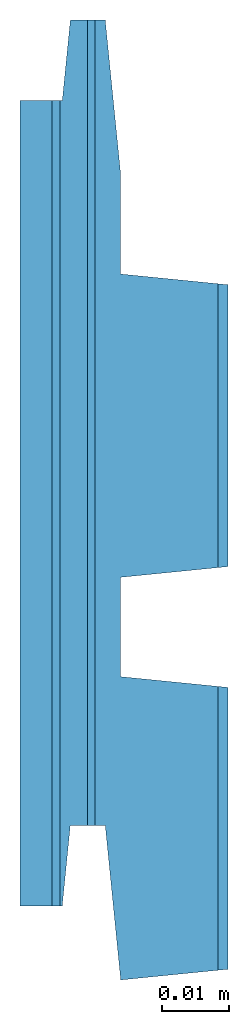
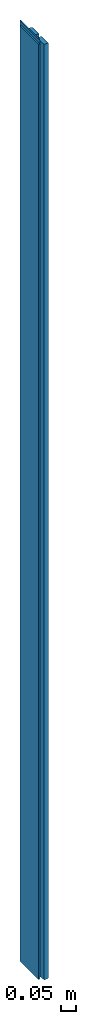
# One storey: 1 beam.
"""IFC2X3 building model written with IfcOpenShell, lengths in metres."""

import ifcopenshell
import ifcopenshell.guid

model = None  # the IFC model being written
_history = None  # IfcOwnerHistory: only IFC2X3 demands one
_inside = {}  # id of a spatial element -> (the spatial element, [elements in it])
_under = {}  # id of a project, library or spatial element -> (it, [spatial elements below it])
_declared = {}  # id of a project -> (the project, [libraries it declares])
_typed = {}  # id of a type object -> (the type object, [elements of that type])
_made_of = {}  # id of a material, layer set ... -> (it, [elements and type objects made of it])


def new_model(schema):
    """Start an empty IFC model of exactly this schema.

    Asked for "IFC4X3", IfcOpenShell would pick the latest addendum, in which some entities
    have other attributes; the version numbers below select the first issue.
    IFC2X3 requires an IfcOwnerHistory on every rooted entity: one is made here for all.
    """
    global model, _history
    if schema == "IFC4X3":
        model = ifcopenshell.file(schema_version=(4, 3, 0, 0))
    else:
        model = ifcopenshell.file(schema=schema)
    _inside.clear()
    _under.clear()
    _declared.clear()
    _typed.clear()
    _made_of.clear()
    _history = None
    if model.schema == "IFC2X3":
        org = make("IfcOrganization", Name="unknown")
        user = make(
            "IfcPersonAndOrganization",
            ThePerson=make("IfcPerson", FamilyName="unknown"),
            TheOrganization=org,
        )
        app = make(
            "IfcApplication",
            ApplicationDeveloper=org,
            Version="unknown",
            ApplicationFullName="unknown",
            ApplicationIdentifier="unknown",
        )
        _history = make(
            "IfcOwnerHistory",
            OwningUser=user,
            OwningApplication=app,
            ChangeAction="ADDED",
            CreationDate=0,
        )
    return model


def make(cls, **values):
    """One entity of the class cls with the attributes given. An attribute that is None is left unset."""
    return model.create_entity(
        cls, **{name: value for name, value in values.items() if value is not None}
    )


def rooted(cls, **values):
    """An entity with a GlobalId (a new one), such as an element, a storey or a relation."""
    return make(cls, GlobalId=ifcopenshell.guid.new(), OwnerHistory=_history, **values)


def si_unit(unit_type, name, prefix=None):
    """IfcSIUnit, for example si_unit("LENGTHUNIT", "METRE", prefix="MILLI")."""
    return make("IfcSIUnit", UnitType=unit_type, Prefix=prefix, Name=name)


def assignment(units):
    """IfcUnitAssignment: the units of a project."""
    return None if units is None else make("IfcUnitAssignment", Units=units)


def point(xyz):
    """IfcCartesianPoint."""
    return None if xyz is None else make("IfcCartesianPoint", Coordinates=xyz)


def direction(xyz):
    """IfcDirection."""
    return None if xyz is None else make("IfcDirection", DirectionRatios=xyz)


def frame(location, z_axis=None, x_axis=None):
    """IfcAxis2Placement3D, a coordinate frame: its origin and axes. An axis left out is left unset."""
    return make(
        "IfcAxis2Placement3D",
        Location=point(location),
        Axis=direction(z_axis),
        RefDirection=direction(x_axis),
    )


def origin_with_axes():
    """The frame at (0, 0, 0) with the z axis (0, 0, 1) and the x axis (1, 0, 0) written out."""
    return frame((0.0, 0.0, 0.0), z_axis=(0.0, 0.0, 1.0), x_axis=(1.0, 0.0, 0.0))


def place(relative_to, where):
    """IfcLocalPlacement: puts the frame where relative to a parent placement (None: the world)."""
    return make(
        "IfcLocalPlacement", PlacementRelTo=relative_to, RelativePlacement=where
    )


def context(
    kind, dimensions, precision=None, world=None, true_north=None, identifier=None
):
    """IfcGeometricRepresentationContext, for example the 3D "Model" context."""
    return make(
        "IfcGeometricRepresentationContext",
        ContextIdentifier=identifier,
        ContextType=kind,
        CoordinateSpaceDimension=dimensions,
        Precision=precision,
        WorldCoordinateSystem=world,
        TrueNorth=true_north,
    )


def project(units=None, contexts=None):
    """IfcProject with its units and contexts."""
    return rooted(
        "IfcProject",
        Name="project",
        RepresentationContexts=contexts,
        UnitsInContext=assignment(units),
    )


def spatial(cls, under=None, at=None, **own):
    """A site, building, storey or space (cls), placed at a placement, below another one or the project."""
    s = rooted(cls, ObjectPlacement=at, **own)
    if under is not None:
        _under.setdefault(under.id(), (under, []))[1].append(s)
    return s


def faces_of(points, faces, orient=None, outer=None):
    """IfcFace entities. A face is a list of loops; a loop is a list of indices into points, from 0.

    orient and outer hold one flag for each loop. By default every Orientation is true, the
    first loop of a face is its IfcFaceOuterBound and the others are IfcFaceBound.
    """
    made = []
    for i, loops in enumerate(faces):
        bounds = []
        for j, loop in enumerate(loops):
            is_outer = j == 0 if outer is None else outer[i][j]
            bounds.append(
                make(
                    "IfcFaceOuterBound" if is_outer else "IfcFaceBound",
                    Bound=make("IfcPolyLoop", Polygon=[points[k] for k in loop]),
                    Orientation=True if orient is None else orient[i][j],
                )
            )
        made.append(make("IfcFace", Bounds=bounds))
    return made


def faceted_brep(points, faces, orient=None, outer=None, voids=None):
    """IfcFacetedBrep: a solid bounded by flat faces; with voids (closed shells), ...WithVoids."""
    shared = [point(p) for p in points]
    hull = make("IfcClosedShell", CfsFaces=faces_of(shared, faces, orient, outer))
    if voids is None:
        return make("IfcFacetedBrep", Outer=hull)
    return make(
        "IfcFacetedBrepWithVoids",
        Outer=hull,
        Voids=[
            make(cls, CfsFaces=faces_of(shared, fs, o, b)) for cls, fs, o, b in voids
        ],
    )


def shape(context_of_items, identifier, shape_type, items):
    """IfcShapeRepresentation: the items that make up one representation, for example the "Body"."""
    return make(
        "IfcShapeRepresentation",
        ContextOfItems=context_of_items,
        RepresentationIdentifier=identifier,
        RepresentationType=shape_type,
        Items=items,
    )


def material(Name=None, Category=None):
    """IfcMaterial."""
    return make("IfcMaterial", Name=Name, Category=Category)


def made_of(thing, what):
    """Note that an element or type object is made of a material, layer set ...; save() writes the relation."""
    if what is not None:
        _made_of.setdefault(what.id(), (what, []))[1].append(thing)
    return thing


def element(
    cls,
    number,
    at=None,
    inside=None,
    cuts=None,
    type_object=None,
    material=None,
    context=None,
    identifier="Body",
    shape_type=None,
    held_by="IfcProductDefinitionShape",
    body=None,
    shapes=None,
    **own,
):
    """One element of the class cls, such as IfcWall. Its Tag is "e" and its number.

    at: its placement. inside: the storey or other place that contains it. cuts: it is an
    opening in that element (IfcRelVoidsElement). A single representation is given by context,
    identifier, shape_type and body (its items); several are given by shapes. held_by: the class
    of the entity that holds the representations. save() writes the other relations.
    """
    e = rooted(cls, Tag="e%d" % number, ObjectPlacement=at, **own)
    if body is not None:
        shapes = [shape(context, identifier, shape_type, body)]
    if shapes is not None:
        e.Representation = make(held_by, Representations=shapes)
    if inside is not None:
        _inside.setdefault(inside.id(), (inside, []))[1].append(e)
    if cuts is not None:
        rooted(
            "IfcRelVoidsElement", RelatingBuildingElement=cuts, RelatedOpeningElement=e
        )
    if type_object is not None:
        _typed.setdefault(type_object.id(), (type_object, []))[1].append(e)
    return made_of(e, material)


def aggregate(whole, parts):
    """IfcRelAggregates: a whole, such as a stair, and the parts it consists of."""
    return rooted("IfcRelAggregates", RelatingObject=whole, RelatedObjects=parts)


def save(model, path):
    """Write the relations noted so far, then the file.

    IfcRelAggregates (storeys below a building ...), IfcRelContainedInSpatialStructure (elements
    in a storey), IfcRelDefinesByType, IfcRelAssociatesMaterial and IfcRelDeclares: one each for
    every whole, place, type object, material and project.
    """
    for whole, parts in _under.values():
        aggregate(whole, parts)
    for where, things in _inside.values():
        rooted(
            "IfcRelContainedInSpatialStructure",
            RelatedElements=things,
            RelatingStructure=where,
        )
    for kind, things in _typed.values():
        rooted("IfcRelDefinesByType", RelatedObjects=things, RelatingType=kind)
    for what, things in _made_of.values():
        rooted("IfcRelAssociatesMaterial", RelatedObjects=things, RelatingMaterial=what)
    for by, libraries in _declared.values():
        rooted("IfcRelDeclares", RelatingContext=by, RelatedDefinitions=libraries)
    model.write(path)


model = new_model("IFC2X3")

# Units and contexts
model_context = context("Model", 3, precision=1e-06, world=origin_with_axes())
ifc_project = project(units=[si_unit("LENGTHUNIT", "METRE"), si_unit("PLANEANGLEUNIT", "RADIAN")], contexts=[model_context])

# Site, building, storey
site_placement = place(None, origin_with_axes())
site = spatial("IfcSite", under=ifc_project, at=site_placement, CompositionType="ELEMENT")
building_placement = place(None, origin_with_axes())
building = spatial("IfcBuilding", under=site, at=building_placement, Name="Building 1", CompositionType="ELEMENT")
storey_placement = place(None, origin_with_axes())
storey = spatial("IfcBuildingStorey", under=building, at=storey_placement, CompositionType="ELEMENT", Elevation=0.0)

# Beam
ifc_material = material()
beam_placement = place(None, frame((0.0155, 0.060475247524942, 3.711500000000033), z_axis=(0.0, -1.0, 0.0), x_axis=(0.0, 0.0, -1.0)))
element("IfcBeam", 1, at=beam_placement, inside=storey, material=ifc_material, context=model_context, shape_type="Brep", body=[
    faceted_brep([(3.711500000000033, 0.014, 0.010075929780351), (3.711500000000033, 0.014, -0.03222475247516), (3.710000000000033, 0.0155, -0.032074752475161), (3.710000000000033, 0.0155, 0.009925929780354), (3.711500000000033, 0.014, 0.070075247524839), (3.711500000000033, 0.014, 0.027774565269321), (3.710000000000033, 0.0155, 0.027924565269324), (3.710000000000033, 0.0155, 0.06992524752484), (3.711500000000033, 0.014, 0.027774565269321), (3.711500000000033, -0.000499999999996, 0.026324565269281), (0.011500000000009, -0.000499999999996, 0.026324565269281), (0.011500000000009, 0.014, 0.027774565269324), (0.01300000000001, 0.015500000000001, 0.027924565269324), (3.710000000000033, 0.0155, 0.027924565269324), (3.711500000000033, 0.014, -0.03222475247516), (3.711500000000033, -0.0005, -0.03367475247516), (0.011500000000009, -0.000499999999999, -0.03367475247516), (0.011500000000009, 0.014, -0.03222475247516), (0.01300000000001, 0.015500000000001, -0.032074752475161), (3.710000000000033, 0.0155, -0.032074752475161), (3.711500000000033, 0.014, 0.070075247524839), (3.711500000000033, -0.000495049502642, 0.071524752475105), (3.711500000000033, -0.002800000000024, 0.048475247524906), (3.711500000000033, -0.004301496268633, 0.048475247524908), (3.711500000000033, -0.004301496268633, -0.071524752475099), (3.711500000000033, -0.002800000000024, -0.071524752475104), (3.711500000000033, -0.0005, -0.048524752474401), (3.711500000000033, -0.0005, -0.03367475247516), (3.711500000000033, 0.014, -0.03222475247516), (3.711500000000033, 0.014, 0.010075929780351), (3.711500000000033, -0.000499999999997, 0.011525929780318), (3.711500000000033, -0.000499999999996, 0.026324565269281), (3.711500000000033, 0.014, 0.027774565269321), (3.711500000000033, -0.004301496268633, -0.071524752475099), (3.711500000000033, -0.004301496268633, 0.048475247524908), (3.699999999999999, -0.005451496268547, 0.048475247524909), (3.699999999999999, -0.005451496268547, -0.071524752475095), (3.699999999999999, -0.009548503728395, 0.060475247524943), (3.699999999999999, -0.009548503728395, -0.059524752475056), (3.699999999999999, -0.009200000000012, -0.059524752475056), (3.699999999999999, -0.008000000000065, -0.071524752475085), (3.699999999999999, -0.005451496268547, -0.071524752475095), (3.699999999999999, -0.005451496268547, 0.048475247524909), (3.699999999999999, -0.008000000000065, 0.048475247524915), (3.699999999999999, -0.009200000000012, 0.060475247524943), (3.699999999999999, -0.009548503728395, -0.059524752475056), (3.699999999999999, -0.009548503728395, 0.060475247524943), (3.711500000000033, -0.010698503728365, 0.060475247524943), (3.711500000000033, -0.010698503728365, -0.059524752475056), (0.0, -0.008000000000064, -0.071524752475085), (0.0, -0.005451496268546, -0.071524752475095), (0.011500000000009, -0.004301496268628, -0.071524752475099), (0.011500000000009, -0.002800000000023, -0.071524752475106), (3.711500000000033, -0.002800000000024, -0.071524752475104), (3.711500000000033, -0.004301496268633, -0.071524752475099), (3.699999999999999, -0.005451496268547, -0.071524752475095), (3.699999999999999, -0.008000000000065, -0.071524752475085), (0.0, -0.008000000000064, -0.071524752475085), (3.699999999999999, -0.008000000000065, -0.071524752475085), (3.699999999999999, -0.009200000000012, -0.059524752475056), (0.0, -0.009200000000011, -0.059524752475056), (3.711500000000033, -0.015500000000001, -0.059524752475056), (0.011500000000033, -0.0155, -0.059524752475056), (0.011500000000033, -0.010698503728364, -0.059524752475056), (0.0, -0.009548503728394, -0.059524752475056), (0.0, -0.009200000000011, -0.059524752475056), (3.699999999999999, -0.009200000000012, -0.059524752475056), (3.699999999999999, -0.009548503728395, -0.059524752475056), (3.711500000000033, -0.010698503728365, -0.059524752475056), (3.711500000000033, -0.015500000000001, -0.059524752475056), (3.711500000000033, -0.010698503728365, -0.059524752475056), (3.711500000000033, -0.010698503728365, 0.060475247524943), (3.711500000000033, -0.015500000000001, 0.060475247524943), (3.710000000000033, 0.0155, -0.032074752475161), (0.01300000000001, 0.015500000000001, -0.032074752475161), (0.01300000000001, 0.015500000000001, 0.009925929780354), (3.710000000000033, 0.0155, 0.009925929780354), (3.710000000000033, 0.0155, 0.009925929780354), (0.01300000000001, 0.015500000000001, 0.009925929780354), (0.011500000000009, 0.014, 0.010075929780355), (0.011500000000009, -0.000499999999996, 0.011525929780318), (3.711500000000033, -0.000499999999997, 0.011525929780318), (3.711500000000033, 0.014, 0.010075929780351), (3.711500000000033, -0.000499999999997, 0.011525929780318), (0.011500000000009, -0.000499999999996, 0.011525929780318), (0.011500000000009, -0.000499999999996, 0.026324565269281), (3.711500000000033, -0.000499999999996, 0.026324565269281), (3.710000000000033, 0.0155, 0.027924565269324), (0.01300000000001, 0.015500000000001, 0.027924565269324), (0.01300000000001, 0.015500000000001, 0.06992524752484), (3.710000000000033, 0.0155, 0.06992524752484), (0.0, -0.009200000000011, 0.060475247524943), (3.699999999999999, -0.009200000000012, 0.060475247524943), (3.699999999999999, -0.008000000000065, 0.048475247524915), (0.0, -0.008000000000064, 0.048475247524915), (0.0, -0.009548503728394, 0.060475247524943), (0.011500000000033, -0.010698503728364, 0.060475247524943), (0.011500000000033, -0.0155, 0.060475247524943), (3.711500000000033, -0.015500000000001, 0.060475247524943), (3.711500000000033, -0.010698503728365, 0.060475247524943), (3.699999999999999, -0.009548503728395, 0.060475247524943), (3.699999999999999, -0.009200000000012, 0.060475247524943), (0.0, -0.009200000000011, 0.060475247524943), (0.0, -0.005451496268546, 0.048475247524909), (0.0, -0.005451496268546, -0.071524752475095), (0.0, -0.008000000000064, -0.071524752475085), (0.0, -0.009200000000011, -0.059524752475056), (0.0, -0.009548503728394, -0.059524752475056), (0.0, -0.009548503728394, 0.060475247524943), (0.0, -0.009200000000011, 0.060475247524943), (0.0, -0.008000000000064, 0.048475247524915), (0.011500000000009, -0.000499999999999, -0.048524752474403), (0.011500000000009, -0.000499999999999, -0.03367475247516), (3.711500000000033, -0.0005, -0.03367475247516), (3.711500000000033, -0.0005, -0.048524752474401), (3.711500000000033, -0.002800000000024, -0.071524752475104), (0.011500000000009, -0.002800000000023, -0.071524752475106), (0.011500000000009, -0.000499999999999, -0.048524752474403), (3.711500000000033, -0.0005, -0.048524752474401), (0.011500000000009, -0.002800000000023, 0.048475247524906), (0.011500000000009, -0.004301496268628, 0.048475247524908), (0.0, -0.005451496268546, 0.048475247524909), (0.0, -0.008000000000064, 0.048475247524915), (3.699999999999999, -0.008000000000065, 0.048475247524915), (3.699999999999999, -0.005451496268547, 0.048475247524909), (3.711500000000033, -0.004301496268633, 0.048475247524908), (3.711500000000033, -0.002800000000024, 0.048475247524906), (0.011500000000009, -0.000495049502641, 0.071524752475103), (0.011500000000009, -0.002800000000023, 0.048475247524906), (3.711500000000033, -0.002800000000024, 0.048475247524906), (3.711500000000033, -0.000495049502642, 0.071524752475105), (3.710000000000033, 0.0155, 0.06992524752484), (0.01300000000001, 0.015500000000001, 0.06992524752484), (0.011500000000009, 0.014, 0.070075247524839), (0.011500000000009, -0.000495049502641, 0.071524752475103), (3.711500000000033, -0.000495049502642, 0.071524752475105), (3.711500000000033, 0.014, 0.070075247524839), (3.711500000000033, -0.015500000000001, 0.060475247524943), (0.011500000000033, -0.0155, 0.060475247524943), (0.011500000000033, -0.0155, -0.059524752475056), (3.711500000000033, -0.015500000000001, -0.059524752475056), (0.011500000000009, 0.014, 0.070075247524839), (0.01300000000001, 0.015500000000001, 0.06992524752484), (0.01300000000001, 0.015500000000001, 0.027924565269324), (0.011500000000009, 0.014, 0.027774565269324), (0.011500000000033, -0.010698503728364, 0.060475247524943), (0.0, -0.009548503728394, 0.060475247524943), (0.0, -0.009548503728394, -0.059524752475056), (0.011500000000033, -0.010698503728364, -0.059524752475056), (0.011500000000009, -0.000499999999996, 0.026324565269281), (0.011500000000009, -0.000499999999996, 0.011525929780318), (0.011500000000009, 0.014, 0.010075929780355), (0.011500000000009, 0.014, -0.03222475247516), (0.011500000000009, -0.000499999999999, -0.03367475247516), (0.011500000000009, -0.000499999999999, -0.048524752474403), (0.011500000000009, -0.002800000000023, -0.071524752475106), (0.011500000000009, -0.004301496268628, -0.071524752475099), (0.011500000000009, -0.004301496268628, 0.048475247524908), (0.011500000000009, -0.002800000000023, 0.048475247524906), (0.011500000000009, -0.000495049502641, 0.071524752475103), (0.011500000000009, 0.014, 0.070075247524839), (0.011500000000009, 0.014, 0.027774565269324), (0.011500000000009, 0.014, -0.03222475247516), (0.011500000000009, 0.014, 0.010075929780355), (0.01300000000001, 0.015500000000001, 0.009925929780354), (0.01300000000001, 0.015500000000001, -0.032074752475161), (0.0, -0.005451496268546, -0.071524752475095), (0.0, -0.005451496268546, 0.048475247524909), (0.011500000000009, -0.004301496268628, 0.048475247524908), (0.011500000000009, -0.004301496268628, -0.071524752475099), (0.011500000000033, -0.0155, -0.059524752475056), (0.011500000000033, -0.0155, 0.060475247524943), (0.011500000000033, -0.010698503728364, 0.060475247524943), (0.011500000000033, -0.010698503728364, -0.059524752475056)], [[[0, 1, 2, 3]], [[4, 5, 6, 7]], [[8, 9, 10, 11, 12, 13]], [[14, 15, 16, 17, 18, 19]], [[20, 21, 22, 23, 24, 25, 26, 27, 28, 29, 30, 31, 32]], [[33, 34, 35, 36]], [[37, 38, 39, 40, 41, 42, 43, 44]], [[45, 46, 47, 48]], [[49, 50, 51, 52, 53, 54, 55, 56]], [[57, 58, 59, 60]], [[61, 62, 63, 64, 65, 66, 67, 68]], [[69, 70, 71, 72]], [[73, 74, 75, 76]], [[77, 78, 79, 80, 81, 82]], [[83, 84, 85, 86]], [[87, 88, 89, 90]], [[91, 92, 93, 94]], [[95, 96, 97, 98, 99, 100, 101, 102]], [[103, 104, 105, 106, 107, 108, 109, 110]], [[111, 112, 113, 114]], [[115, 116, 117, 118]], [[119, 120, 121, 122, 123, 124, 125, 126]], [[127, 128, 129, 130]], [[131, 132, 133, 134, 135, 136]], [[137, 138, 139, 140]], [[141, 142, 143, 144]], [[145, 146, 147, 148]], [[149, 150, 151, 152, 153, 154, 155, 156, 157, 158, 159, 160, 161]], [[162, 163, 164, 165]], [[166, 167, 168, 169]], [[170, 171, 172, 173]]]),
])

save(model, "model.ifc")
